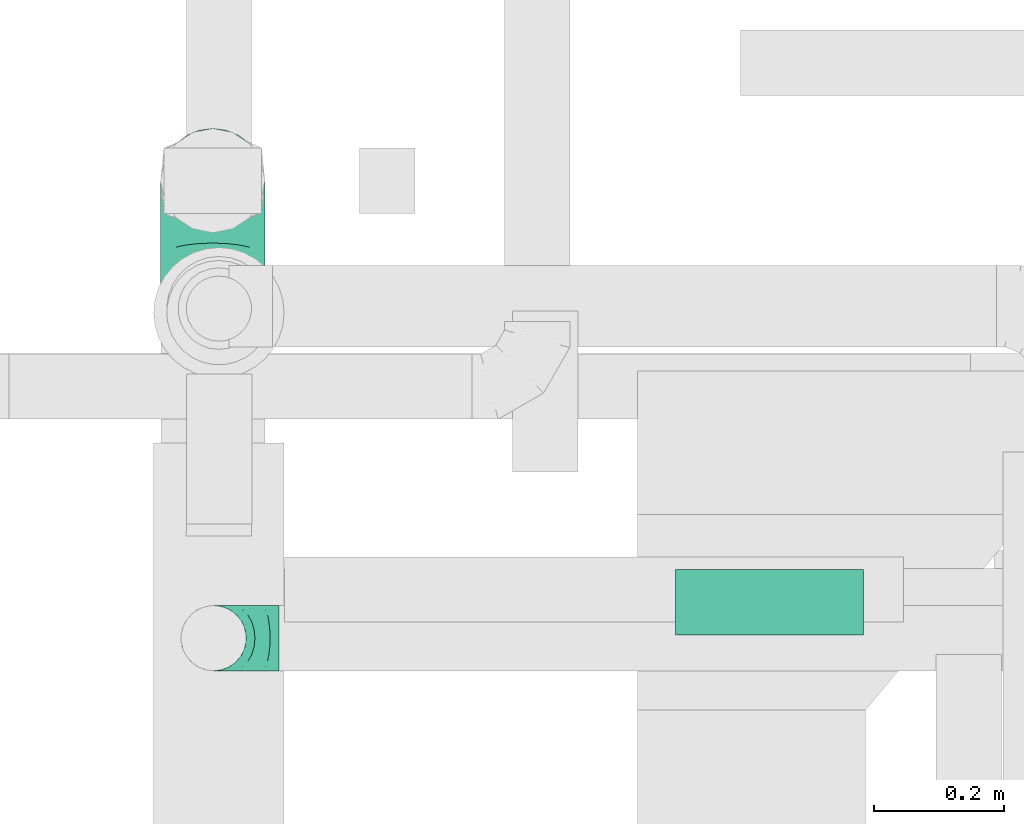
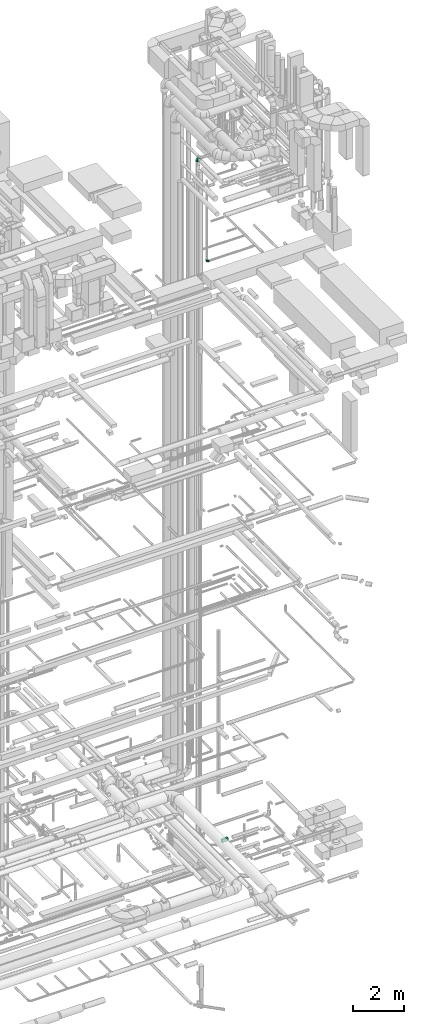
# One storey, part 265 of 337: 2 flow fittings, 1 flow segment.
"""IFC2X3 building model written with IfcOpenShell, lengths in millimetres."""

from ifc_helpers import new_model, entity, si_unit, converted_unit, derived_unit, direction, frame, origin, origin_2d_with_axis, place, context, subcontext, project, spatial, rectangle, extrude, faceted_brep, source, transform, mapped, material, type_object, type_shapes, element, save


model = new_model("IFC2X3")

# Units and contexts
model_context = context("Model", 3, precision=0.01, world=origin(), true_north=direction((6.12303176911189e-17, 1.0)))
body_context = subcontext(model_context, "Body", "Model", "MODEL_VIEW")
ifc_project = project(units=[si_unit("LENGTHUNIT", "METRE", prefix="MILLI"), si_unit("AREAUNIT", "SQUARE_METRE"), si_unit("VOLUMEUNIT", "CUBIC_METRE"), converted_unit("PLANEANGLEUNIT", "DEGREE", entity("IfcRatioMeasure", 0.0174532925199433), si_unit("PLANEANGLEUNIT", "RADIAN"), dimensions=[0, 0, 0, 0, 0, 0, 0]), si_unit("MASSUNIT", "GRAM", prefix="KILO"), derived_unit("MASSDENSITYUNIT", [(si_unit("MASSUNIT", "GRAM", prefix="KILO"), 1), (si_unit("LENGTHUNIT", "METRE"), -3)]), derived_unit("MOMENTOFINERTIAUNIT", [(si_unit("LENGTHUNIT", "METRE"), 4)]), si_unit("TIMEUNIT", "SECOND"), si_unit("FREQUENCYUNIT", "HERTZ"), si_unit("THERMODYNAMICTEMPERATUREUNIT", "DEGREE_CELSIUS"), derived_unit("THERMALTRANSMITTANCEUNIT", [(si_unit("MASSUNIT", "GRAM", prefix="KILO"), 1), (si_unit("THERMODYNAMICTEMPERATUREUNIT", "KELVIN"), -1), (si_unit("TIMEUNIT", "SECOND"), -3)]), derived_unit("VOLUMETRICFLOWRATEUNIT", [(si_unit("LENGTHUNIT", "METRE"), 3), (si_unit("TIMEUNIT", "SECOND"), -1)]), derived_unit("MASSFLOWRATEUNIT", [(si_unit("MASSUNIT", "GRAM", prefix="KILO"), 1), (si_unit("TIMEUNIT", "SECOND"), -1)]), derived_unit("ROTATIONALFREQUENCYUNIT", [(si_unit("TIMEUNIT", "SECOND"), -1)]), si_unit("ELECTRICCURRENTUNIT", "AMPERE"), si_unit("ELECTRICVOLTAGEUNIT", "VOLT"), si_unit("POWERUNIT", "WATT"), si_unit("FORCEUNIT", "NEWTON", prefix="KILO"), si_unit("ILLUMINANCEUNIT", "LUX"), si_unit("LUMINOUSFLUXUNIT", "LUMEN"), si_unit("LUMINOUSINTENSITYUNIT", "CANDELA"), derived_unit("USERDEFINED", [(si_unit("MASSUNIT", "GRAM", prefix="KILO"), -1), (si_unit("LENGTHUNIT", "METRE"), -2), (si_unit("TIMEUNIT", "SECOND"), 3), (si_unit("LUMINOUSFLUXUNIT", "LUMEN"), 1)]), derived_unit("LINEARVELOCITYUNIT", [(si_unit("LENGTHUNIT", "METRE"), 1), (si_unit("TIMEUNIT", "SECOND"), -1)]), si_unit("PRESSUREUNIT", "PASCAL"), derived_unit("USERDEFINED", [(si_unit("LENGTHUNIT", "METRE"), -2), (si_unit("MASSUNIT", "GRAM", prefix="KILO"), 1), (si_unit("TIMEUNIT", "SECOND"), -2)]), derived_unit("LINEARFORCEUNIT", [(si_unit("MASSUNIT", "GRAM", prefix="KILO"), 1), (si_unit("LENGTHUNIT", "METRE"), 1), (si_unit("TIMEUNIT", "SECOND"), -2), (si_unit("LENGTHUNIT", "METRE"), -1)]), derived_unit("PLANARFORCEUNIT", [(si_unit("MASSUNIT", "GRAM", prefix="KILO"), 1), (si_unit("LENGTHUNIT", "METRE"), 1), (si_unit("TIMEUNIT", "SECOND"), -2), (si_unit("LENGTHUNIT", "METRE"), -2)])], contexts=[model_context])

# Site, building, storey
site_placement = place(None, origin())
site = spatial("IfcSite", under=ifc_project, at=site_placement, CompositionType="ELEMENT")
building_placement = place(site_placement, origin())
building = spatial("IfcBuilding", under=site, at=building_placement, CompositionType="ELEMENT")
storey_placement = place(building_placement, origin())
storey = spatial("IfcBuildingStorey", under=building, at=storey_placement, CompositionType="ELEMENT", Elevation=0.0)

# Flow segment
duct_segment_type = type_object("IfcDuctSegmentType", PredefinedType="NOTDEFINED")
flow_segment_placement = place(storey_placement, frame((69314.1, 11173.58, -750.0)))
element("IfcFlowSegment", 1, at=flow_segment_placement, inside=storey, type_object=duct_segment_type, context=body_context, shape_type="SweptSolid", body=[
    extrude(rectangle(XDim=287.766589999998, YDim=100.000000000001, at=origin_2d_with_axis()), frame((143.88, 50.0, 0.0)), (0.0, 0.0, 1.0), 150.0),
])

# Flow fittings
ifc_material = material()
duct_fitting_type_1 = type_object("IfcDuctFittingType", PredefinedType="NOTDEFINED", material=ifc_material)
shared_shape_1 = source(origin(), body_context, "Body", "Brep", [
    faceted_brep([(-160.0, 0.0, -80.0), (-160.0, -20.71, -77.27), (-160.0, -40.0, -69.28), (-160.0, -56.57, -56.57), (-160.0, -69.28, -40.0), (-160.0, -77.27, -20.71), (-160.0, -80.0, 0.0), (-160.0, -77.27, 20.71), (-160.0, -69.28, 40.0), (-160.0, -56.57, 56.57), (-160.0, -40.0, 69.28), (-160.0, -20.71, 77.27), (-160.0, 0.0, 80.0), (-160.0, 20.71, 77.27), (-160.0, 40.0, 69.28), (-160.0, 56.57, 56.57), (-160.0, 69.28, 40.0), (-160.0, 77.27, 20.71), (-160.0, 80.0, 0.0), (-160.0, 77.27, -20.71), (-160.0, 69.28, -40.0), (-160.0, 56.57, -56.57), (-160.0, 40.0, -69.28), (-160.0, 20.71, -77.27), (-122.68, 20.71, 77.27), (-127.85, 40.0, 69.28), (-117.13, 0.0, 80.0), (-132.29, 56.57, 56.57), (-137.83, 77.27, 20.71), (-138.56, 80.0, 0.0), (-135.69, 69.28, 40.0), (-135.69, 69.28, -40.0), (-132.29, 56.57, -56.57), (-137.83, 77.27, -20.71), (-122.68, 20.71, -77.27), (-117.13, 0.0, -80.0), (-127.85, 40.0, -69.28), (-111.58, -20.71, -77.27), (-106.41, -40.0, -69.28), (-101.97, -56.57, -56.57), (-98.56, -69.28, -40.0), (-96.42, -77.27, -20.71), (-95.69, -80.0, 0.0), (-96.42, -77.27, 20.71), (-98.56, -69.28, 40.0), (-101.97, -56.57, 56.57), (-106.41, -40.0, 69.28), (-111.58, -20.71, 77.27), (-58.03, 58.03, 77.27), (-72.15, 72.15, 69.28), (-42.87, 42.87, 80.0), (-84.28, 84.28, 56.57), (-93.59, 93.59, 40.0), (-99.44, 99.44, 20.71), (-101.44, 101.44, 0.0), (-99.44, 99.44, -20.71), (-93.59, 93.59, -40.0), (-84.28, 84.28, -56.57), (-58.03, 58.03, -77.27), (-42.87, 42.87, -80.0), (-72.15, 72.15, -69.28), (-27.71, 27.71, -77.27), (-13.59, 13.59, -69.28), (-1.46, 1.46, -56.57), (7.85, -7.85, -40.0), (13.7, -13.7, -20.71), (15.69, -15.69, 0.0), (13.7, -13.7, 20.71), (7.85, -7.85, 40.0), (-1.46, 1.46, 56.57), (-13.59, 13.59, 69.28), (-27.71, 27.71, 77.27), (-20.71, 122.68, 77.27), (-40.0, 127.85, 69.28), (0.0, 117.13, 80.0), (-56.57, 132.29, 56.57), (-69.28, 135.69, 40.0), (-77.27, 137.83, 20.71), (-80.0, 138.56, 0.0), (-77.27, 137.83, -20.71), (-69.28, 135.69, -40.0), (-56.57, 132.29, -56.57), (-20.71, 122.68, -77.27), (0.0, 117.13, -80.0), (-40.0, 127.85, -69.28), (20.71, 111.58, -77.27), (40.0, 106.41, -69.28), (56.57, 101.97, -56.57), (69.28, 98.56, -40.0), (77.27, 96.42, -20.71), (80.0, 95.69, 0.0), (77.27, 96.42, 20.71), (69.28, 98.56, 40.0), (56.57, 101.97, 56.57), (40.0, 106.41, 69.28), (20.71, 111.58, 77.27), (-20.71, 160.0, -77.27), (-40.0, 160.0, -69.28), (-56.57, 160.0, -56.57), (-69.28, 160.0, -40.0), (-77.27, 160.0, -20.71), (-80.0, 160.0, 0.0), (-77.27, 160.0, 20.71), (-69.28, 160.0, 40.0), (-56.57, 160.0, 56.57), (-40.0, 160.0, 69.28), (-20.71, 160.0, 77.27), (0.0, 160.0, 80.0), (20.71, 160.0, 77.27), (40.0, 160.0, 69.28), (56.57, 160.0, 56.57), (69.28, 160.0, 40.0), (77.27, 160.0, 20.71), (80.0, 160.0, 0.0), (77.27, 160.0, -20.71), (69.28, 160.0, -40.0), (56.57, 160.0, -56.57), (40.0, 160.0, -69.28), (20.71, 160.0, -77.27), (0.0, 160.0, -80.0)], [[[0, 1, 2, 3, 4, 5, 6, 7, 8, 9, 10, 11, 12, 13, 14, 15, 16, 17, 18, 19, 20, 21, 22, 23]], [[24, 25, 14, 13]], [[26, 24, 13, 12]], [[14, 25, 27, 15]], [[28, 29, 18, 17]], [[30, 28, 17, 16]], [[15, 27, 30, 16]], [[20, 31, 32, 21]], [[33, 31, 20, 19]], [[18, 29, 33, 19]], [[34, 35, 0, 23]], [[36, 34, 23, 22]], [[32, 36, 22, 21]], [[1, 0, 35, 37]], [[2, 1, 37, 38]], [[3, 2, 38, 39]], [[5, 4, 40, 41]], [[6, 5, 41, 42]], [[39, 40, 4, 3]], [[6, 42, 43, 7]], [[7, 43, 44, 8]], [[8, 44, 45, 9]], [[9, 45, 46, 10]], [[10, 46, 47, 11]], [[26, 12, 11, 47]], [[48, 49, 25, 24]], [[50, 48, 24, 26]], [[27, 25, 49, 51]], [[52, 53, 28, 30]], [[51, 52, 30, 27]], [[29, 28, 53, 54]], [[55, 56, 31, 33]], [[54, 55, 33, 29]], [[32, 31, 56, 57]], [[58, 59, 35, 34]], [[60, 58, 34, 36]], [[57, 60, 36, 32]], [[37, 35, 59, 61]], [[38, 37, 61, 62]], [[39, 38, 62, 63]], [[41, 40, 64, 65]], [[42, 41, 65, 66]], [[63, 64, 40, 39]], [[43, 42, 66, 67]], [[44, 43, 67, 68]], [[68, 69, 45, 44]], [[46, 45, 69, 70]], [[47, 46, 70, 71]], [[26, 47, 71, 50]], [[72, 73, 49, 48]], [[74, 72, 48, 50]], [[51, 49, 73, 75]], [[76, 77, 53, 52]], [[75, 76, 52, 51]], [[54, 53, 77, 78]], [[79, 80, 56, 55]], [[78, 79, 55, 54]], [[57, 56, 80, 81]], [[82, 83, 59, 58]], [[84, 82, 58, 60]], [[81, 84, 60, 57]], [[61, 59, 83, 85]], [[62, 61, 85, 86]], [[63, 62, 86, 87]], [[65, 64, 88, 89]], [[66, 65, 89, 90]], [[87, 88, 64, 63]], [[67, 66, 90, 91]], [[68, 67, 91, 92]], [[92, 93, 69, 68]], [[70, 69, 93, 94]], [[71, 70, 94, 95]], [[50, 71, 95, 74]], [[96, 97, 98, 99, 100, 101, 102, 103, 104, 105, 106, 107, 108, 109, 110, 111, 112, 113, 114, 115, 116, 117, 118, 119]], [[72, 74, 107, 106]], [[73, 72, 106, 105]], [[75, 73, 105, 104]], [[77, 76, 103, 102]], [[78, 77, 102, 101]], [[75, 104, 103, 76]], [[78, 101, 100, 79]], [[79, 100, 99, 80]], [[80, 99, 98, 81]], [[84, 97, 96, 82]], [[82, 96, 119, 83]], [[84, 81, 98, 97]], [[118, 117, 86, 85]], [[119, 118, 85, 83]], [[116, 87, 86, 117]], [[88, 115, 114, 89]], [[89, 114, 113, 90]], [[115, 88, 87, 116]], [[112, 111, 92, 91]], [[113, 112, 91, 90]], [[111, 110, 93, 92]], [[95, 94, 109, 108]], [[74, 95, 108, 107]], [[110, 109, 94, 93]]]),
])
type_shapes(duct_fitting_type_1, [shared_shape_1])
flow_fitting_1_placement = place(storey_placement, frame((68604.23, 11870.03, 31900.0), z_axis=(1.0, 0.0, 0.0), x_axis=(0.0, 0.0, 1.0)))
element("IfcFlowFitting", 2, at=flow_fitting_1_placement, inside=storey, type_object=duct_fitting_type_1, material=ifc_material, context=body_context, shape_type="MappedRepresentation", body=[
    mapped(shared_shape_1, transform((0.0, 0.0, 0.0), scale=1.0)),
])
duct_fitting_type_2 = type_object("IfcDuctFittingType", PredefinedType="NOTDEFINED", material=ifc_material)
shared_shape_2 = source(origin(), body_context, "Body", "Brep", [
    faceted_brep([(-100.0, 0.0, -50.0), (-100.0, -12.94, -48.3), (-100.0, -25.0, -43.3), (-100.0, -35.36, -35.36), (-100.0, -43.3, -25.0), (-100.0, -48.3, -12.94), (-100.0, -50.0, 0.0), (-100.0, -48.3, 12.94), (-100.0, -43.3, 25.0), (-100.0, -35.36, 35.36), (-100.0, -25.0, 43.3), (-100.0, -12.94, 48.3), (-100.0, 0.0, 50.0), (-100.0, 12.94, 48.3), (-100.0, 25.0, 43.3), (-100.0, 35.36, 35.36), (-100.0, 43.3, 25.0), (-100.0, 48.3, 12.94), (-100.0, 50.0, 0.0), (-100.0, 48.3, -12.94), (-100.0, 43.3, -25.0), (-100.0, 35.36, -35.36), (-100.0, 25.0, -43.3), (-100.0, 12.94, -48.3), (-76.67, 12.94, 48.3), (-79.9, 25.0, 43.3), (-73.21, 0.0, 50.0), (-82.68, 35.36, 35.36), (-86.15, 48.3, 12.94), (-86.6, 50.0, 0.0), (-84.81, 43.3, 25.0), (-84.81, 43.3, -25.0), (-82.68, 35.36, -35.36), (-86.15, 48.3, -12.94), (-76.67, 12.94, -48.3), (-73.21, 0.0, -50.0), (-79.9, 25.0, -43.3), (-69.74, -12.94, -48.3), (-66.51, -25.0, -43.3), (-63.73, -35.36, -35.36), (-61.6, -43.3, -25.0), (-60.26, -48.3, -12.94), (-59.81, -50.0, 0.0), (-60.26, -48.3, 12.94), (-61.6, -43.3, 25.0), (-63.73, -35.36, 35.36), (-66.51, -25.0, 43.3), (-69.74, -12.94, 48.3), (-36.27, 36.27, 48.3), (-45.1, 45.1, 43.3), (-26.79, 26.79, 50.0), (-52.68, 52.68, 35.36), (-58.49, 58.49, 25.0), (-62.15, 62.15, 12.94), (-63.4, 63.4, 0.0), (-62.15, 62.15, -12.94), (-58.49, 58.49, -25.0), (-52.68, 52.68, -35.36), (-36.27, 36.27, -48.3), (-26.79, 26.79, -50.0), (-45.1, 45.1, -43.3), (-17.32, 17.32, -48.3), (-8.49, 8.49, -43.3), (-0.91, 0.91, -35.36), (4.9, -4.9, -25.0), (8.56, -8.56, -12.94), (9.81, -9.81, 0.0), (8.56, -8.56, 12.94), (4.9, -4.9, 25.0), (-0.91, 0.91, 35.36), (-8.49, 8.49, 43.3), (-17.32, 17.32, 48.3), (-12.94, 76.67, 48.3), (-25.0, 79.9, 43.3), (0.0, 73.21, 50.0), (-35.36, 82.68, 35.36), (-43.3, 84.81, 25.0), (-48.3, 86.15, 12.94), (-50.0, 86.6, 0.0), (-48.3, 86.15, -12.94), (-43.3, 84.81, -25.0), (-35.36, 82.68, -35.36), (-12.94, 76.67, -48.3), (0.0, 73.21, -50.0), (-25.0, 79.9, -43.3), (12.94, 69.74, -48.3), (25.0, 66.51, -43.3), (35.36, 63.73, -35.36), (43.3, 61.6, -25.0), (48.3, 60.26, -12.94), (50.0, 59.81, 0.0), (48.3, 60.26, 12.94), (43.3, 61.6, 25.0), (35.36, 63.73, 35.36), (25.0, 66.51, 43.3), (12.94, 69.74, 48.3), (-12.94, 100.0, -48.3), (-25.0, 100.0, -43.3), (-35.36, 100.0, -35.36), (-43.3, 100.0, -25.0), (-48.3, 100.0, -12.94), (-50.0, 100.0, 0.0), (-48.3, 100.0, 12.94), (-43.3, 100.0, 25.0), (-35.36, 100.0, 35.36), (-25.0, 100.0, 43.3), (-12.94, 100.0, 48.3), (0.0, 100.0, 50.0), (12.94, 100.0, 48.3), (25.0, 100.0, 43.3), (35.36, 100.0, 35.36), (43.3, 100.0, 25.0), (48.3, 100.0, 12.94), (50.0, 100.0, 0.0), (48.3, 100.0, -12.94), (43.3, 100.0, -25.0), (35.36, 100.0, -35.36), (25.0, 100.0, -43.3), (12.94, 100.0, -48.3), (0.0, 100.0, -50.0)], [[[0, 1, 2, 3, 4, 5, 6, 7, 8, 9, 10, 11, 12, 13, 14, 15, 16, 17, 18, 19, 20, 21, 22, 23]], [[24, 25, 14, 13]], [[26, 24, 13, 12]], [[14, 25, 27, 15]], [[28, 29, 18, 17]], [[30, 28, 17, 16]], [[15, 27, 30, 16]], [[20, 31, 32, 21]], [[33, 31, 20, 19]], [[18, 29, 33, 19]], [[34, 35, 0, 23]], [[36, 34, 23, 22]], [[32, 36, 22, 21]], [[2, 1, 37, 38]], [[3, 2, 38, 39]], [[0, 35, 37, 1]], [[5, 4, 40, 41]], [[6, 5, 41, 42]], [[3, 39, 40, 4]], [[6, 42, 43, 7]], [[7, 43, 44, 8]], [[8, 44, 45, 9]], [[10, 46, 47, 11]], [[11, 47, 26, 12]], [[10, 9, 45, 46]], [[48, 49, 25, 24]], [[50, 48, 24, 26]], [[27, 25, 49, 51]], [[52, 53, 28, 30]], [[51, 52, 30, 27]], [[29, 28, 53, 54]], [[55, 56, 31, 33]], [[54, 55, 33, 29]], [[57, 32, 31, 56]], [[58, 59, 35, 34]], [[60, 58, 34, 36]], [[57, 60, 36, 32]], [[37, 35, 59, 61]], [[38, 37, 61, 62]], [[39, 38, 62, 63]], [[41, 40, 64, 65]], [[42, 41, 65, 66]], [[63, 64, 40, 39]], [[43, 42, 66, 67]], [[44, 43, 67, 68]], [[68, 69, 45, 44]], [[46, 45, 69, 70]], [[47, 46, 70, 71]], [[26, 47, 71, 50]], [[72, 73, 49, 48]], [[74, 72, 48, 50]], [[51, 49, 73, 75]], [[76, 77, 53, 52]], [[75, 76, 52, 51]], [[54, 53, 77, 78]], [[79, 80, 56, 55]], [[78, 79, 55, 54]], [[81, 57, 56, 80]], [[82, 83, 59, 58]], [[84, 82, 58, 60]], [[81, 84, 60, 57]], [[61, 59, 83, 85]], [[62, 61, 85, 86]], [[63, 62, 86, 87]], [[65, 64, 88, 89]], [[66, 65, 89, 90]], [[87, 88, 64, 63]], [[67, 66, 90, 91]], [[68, 67, 91, 92]], [[92, 93, 69, 68]], [[70, 69, 93, 94]], [[71, 70, 94, 95]], [[50, 71, 95, 74]], [[96, 97, 98, 99, 100, 101, 102, 103, 104, 105, 106, 107, 108, 109, 110, 111, 112, 113, 114, 115, 116, 117, 118, 119]], [[72, 74, 107, 106]], [[73, 72, 106, 105]], [[75, 73, 105, 104]], [[77, 76, 103, 102]], [[78, 77, 102, 101]], [[75, 104, 103, 76]], [[78, 101, 100, 79]], [[79, 100, 99, 80]], [[80, 99, 98, 81]], [[96, 119, 83, 82]], [[97, 96, 82, 84]], [[84, 81, 98, 97]], [[83, 119, 118, 85]], [[85, 118, 117, 86]], [[86, 117, 116, 87]], [[88, 115, 114, 89]], [[89, 114, 113, 90]], [[87, 116, 115, 88]], [[91, 90, 113, 112]], [[92, 91, 112, 111]], [[93, 92, 111, 110]], [[95, 94, 109, 108]], [[74, 95, 108, 107]], [[110, 109, 94, 93]]]),
])
type_shapes(duct_fitting_type_2, [shared_shape_2])
flow_fitting_2_placement = place(storey_placement, frame((68605.54, 11168.54, 27350.0), z_axis=(0.0, -1.0, 0.0), x_axis=(0.0, 0.0, -1.0)))
element("IfcFlowFitting", 3, at=flow_fitting_2_placement, inside=storey, type_object=duct_fitting_type_2, material=ifc_material, context=body_context, shape_type="MappedRepresentation", body=[
    mapped(shared_shape_2, transform((0.0, 0.0, 0.0), scale=1.0)),
])

save(model, "model.ifc")
